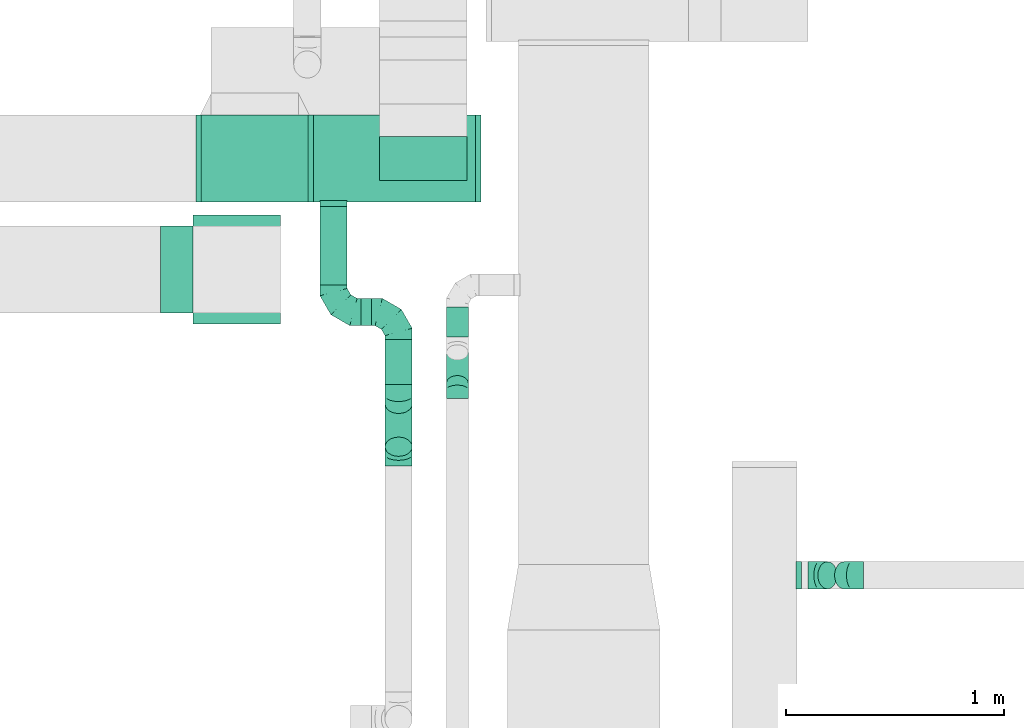
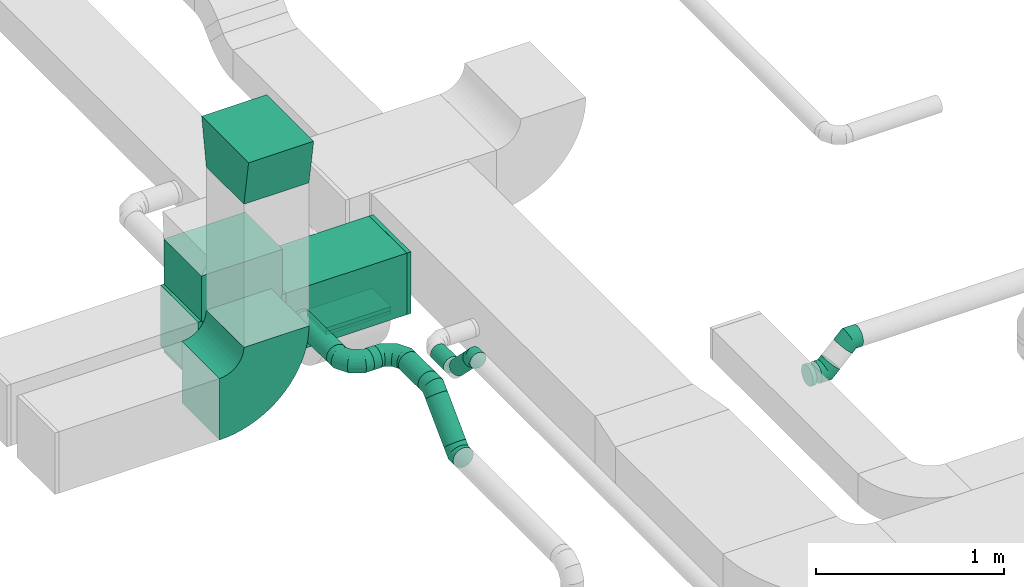
# One storey, part 30 of 60: 16 flow fittings, 9 flow segments.
"""IFC2X3 building model written with IfcOpenShell, lengths in millimetres."""

import ifcopenshell
import ifcopenshell.guid

model = None  # the IFC model being written
_history = None  # IfcOwnerHistory: only IFC2X3 demands one
_inside = {}  # id of a spatial element -> (the spatial element, [elements in it])
_under = {}  # id of a project, library or spatial element -> (it, [spatial elements below it])
_declared = {}  # id of a project -> (the project, [libraries it declares])
_typed = {}  # id of a type object -> (the type object, [elements of that type])
_made_of = {}  # id of a material, layer set ... -> (it, [elements and type objects made of it])


def new_model(schema):
    """Start an empty IFC model of exactly this schema.

    Asked for "IFC4X3", IfcOpenShell would pick the latest addendum, in which some entities
    have other attributes; the version numbers below select the first issue.
    IFC2X3 requires an IfcOwnerHistory on every rooted entity: one is made here for all.
    """
    global model, _history
    if schema == "IFC4X3":
        model = ifcopenshell.file(schema_version=(4, 3, 0, 0))
    else:
        model = ifcopenshell.file(schema=schema)
    _inside.clear()
    _under.clear()
    _declared.clear()
    _typed.clear()
    _made_of.clear()
    _history = None
    if model.schema == "IFC2X3":
        org = make("IfcOrganization", Name="unknown")
        user = make(
            "IfcPersonAndOrganization",
            ThePerson=make("IfcPerson", FamilyName="unknown"),
            TheOrganization=org,
        )
        app = make(
            "IfcApplication",
            ApplicationDeveloper=org,
            Version="unknown",
            ApplicationFullName="unknown",
            ApplicationIdentifier="unknown",
        )
        _history = make(
            "IfcOwnerHistory",
            OwningUser=user,
            OwningApplication=app,
            ChangeAction="ADDED",
            CreationDate=0,
        )
    return model


def make(cls, **values):
    """One entity of the class cls with the attributes given. An attribute that is None is left unset."""
    return model.create_entity(
        cls, **{name: value for name, value in values.items() if value is not None}
    )


def entity(cls, *values):
    """Any entity or typed value of the class cls, its attributes in the order of the schema. None: left unset."""
    e = model.create_entity(cls)
    for i, value in enumerate(values):
        if value is not None:
            e[i] = value
    return e


def rooted(cls, **values):
    """An entity with a GlobalId (a new one), such as an element, a storey or a relation."""
    return make(cls, GlobalId=ifcopenshell.guid.new(), OwnerHistory=_history, **values)


def si_unit(unit_type, name, prefix=None):
    """IfcSIUnit, for example si_unit("LENGTHUNIT", "METRE", prefix="MILLI")."""
    return make("IfcSIUnit", UnitType=unit_type, Prefix=prefix, Name=name)


def converted_unit(unit_type, name, factor, base, dimensions=None, offset=None):
    """IfcConversionBasedUnit, such as the inch: factor (a typed value) times the base unit."""
    return make(
        "IfcConversionBasedUnit"
        if offset is None
        else "IfcConversionBasedUnitWithOffset",
        ConversionOffset=offset,
        Dimensions=None
        if dimensions is None
        else entity("IfcDimensionalExponents", *dimensions),
        UnitType=unit_type,
        Name=name,
        ConversionFactor=make(
            "IfcMeasureWithUnit", ValueComponent=factor, UnitComponent=base
        ),
    )


def derived_unit(unit_type, elements):
    """IfcDerivedUnit: a product of units, each with its exponent."""
    return make(
        "IfcDerivedUnit",
        Elements=[
            make("IfcDerivedUnitElement", Unit=unit, Exponent=power)
            for unit, power in elements
        ],
        UnitType=unit_type,
    )


def assignment(units):
    """IfcUnitAssignment: the units of a project."""
    return None if units is None else make("IfcUnitAssignment", Units=units)


def point(xyz):
    """IfcCartesianPoint."""
    return None if xyz is None else make("IfcCartesianPoint", Coordinates=xyz)


def direction(xyz):
    """IfcDirection."""
    return None if xyz is None else make("IfcDirection", DirectionRatios=xyz)


def frame(location, z_axis=None, x_axis=None):
    """IfcAxis2Placement3D, a coordinate frame: its origin and axes. An axis left out is left unset."""
    return make(
        "IfcAxis2Placement3D",
        Location=point(location),
        Axis=direction(z_axis),
        RefDirection=direction(x_axis),
    )


def frame_2d(location, x_axis=None):
    """IfcAxis2Placement2D, a coordinate frame in the plane: its origin and x axis."""
    return make(
        "IfcAxis2Placement2D", Location=point(location), RefDirection=direction(x_axis)
    )


def origin():
    """The frame at (0, 0, 0) with its axes left unset."""
    return frame((0.0, 0.0, 0.0))


def origin_2d_with_axis():
    """The frame at (0, 0) in the plane with the x axis (1, 0) written out."""
    return frame_2d((0.0, 0.0), x_axis=(1.0, 0.0))


def place(relative_to, where):
    """IfcLocalPlacement: puts the frame where relative to a parent placement (None: the world)."""
    return make(
        "IfcLocalPlacement", PlacementRelTo=relative_to, RelativePlacement=where
    )


def context(
    kind, dimensions, precision=None, world=None, true_north=None, identifier=None
):
    """IfcGeometricRepresentationContext, for example the 3D "Model" context."""
    return make(
        "IfcGeometricRepresentationContext",
        ContextIdentifier=identifier,
        ContextType=kind,
        CoordinateSpaceDimension=dimensions,
        Precision=precision,
        WorldCoordinateSystem=world,
        TrueNorth=true_north,
    )


def subcontext(parent, identifier, kind, view, scale=None):
    """IfcGeometricRepresentationSubContext, for example "Body" below "Model"."""
    return make(
        "IfcGeometricRepresentationSubContext",
        ContextIdentifier=identifier,
        ContextType=kind,
        ParentContext=parent,
        TargetScale=scale,
        TargetView=view,
    )


def project(units=None, contexts=None):
    """IfcProject with its units and contexts."""
    return rooted(
        "IfcProject",
        Name="project",
        RepresentationContexts=contexts,
        UnitsInContext=assignment(units),
    )


def spatial(cls, under=None, at=None, **own):
    """A site, building, storey or space (cls), placed at a placement, below another one or the project."""
    s = rooted(cls, ObjectPlacement=at, **own)
    if under is not None:
        _under.setdefault(under.id(), (under, []))[1].append(s)
    return s


def polyline(points):
    """IfcPolyline through the points."""
    return make("IfcPolyline", Points=[point(p) for p in points])


def circle_curve(where, radius):
    """IfcCircle in the frame where."""
    return make("IfcCircle", Position=where, Radius=radius)


def parameter(value):
    """IfcParameterValue: where a trimmed curve begins or ends, as a parameter of its basis curve."""
    return model.create_entity("IfcParameterValue", value)


def trimmed(basis, trim1, trim2, sense, master):
    """IfcTrimmedCurve: the piece of a basis curve between two trims."""
    return make(
        "IfcTrimmedCurve",
        BasisCurve=basis,
        Trim1=trim1,
        Trim2=trim2,
        SenseAgreement=sense,
        MasterRepresentation=master,
    )


def segment(curve, same_sense, transition):
    """IfcCompositeCurveSegment."""
    return make(
        "IfcCompositeCurveSegment",
        Transition=transition,
        SameSense=same_sense,
        ParentCurve=curve,
    )


def composite_curve(segments, self_intersect=None):
    """IfcCompositeCurve: segments joined end to end."""
    return make("IfcCompositeCurve", Segments=segments, SelfIntersect=self_intersect)


def profile(cls, at=None, kind="AREA", **sizes):
    """A parametric profile (cls). Its sizes go by their IFC names, for example OverallWidth=200.0."""
    return make(cls, ProfileType=kind, Position=at, **sizes)


def rectangle(**sizes):
    """IfcRectangleProfileDef."""
    return profile("IfcRectangleProfileDef", **sizes)


def circle(**sizes):
    """IfcCircleProfileDef."""
    return profile("IfcCircleProfileDef", **sizes)


def outline(outer, holes=None, kind="AREA"):
    """IfcArbitraryClosedProfileDef: a profile drawn as a closed curve; with holes, ...WithVoids."""
    if holes is None:
        return make("IfcArbitraryClosedProfileDef", ProfileType=kind, OuterCurve=outer)
    return make(
        "IfcArbitraryProfileDefWithVoids",
        ProfileType=kind,
        OuterCurve=outer,
        InnerCurves=holes,
    )


def extrude(swept, where, along, depth):
    """IfcExtrudedAreaSolid: the profile swept, set in the frame where, extruded along a direction by depth."""
    return make(
        "IfcExtrudedAreaSolid",
        SweptArea=swept,
        Position=where,
        ExtrudedDirection=direction(along),
        Depth=depth,
    )


def faces_of(points, faces, orient=None, outer=None):
    """IfcFace entities. A face is a list of loops; a loop is a list of indices into points, from 0.

    orient and outer hold one flag for each loop. By default every Orientation is true, the
    first loop of a face is its IfcFaceOuterBound and the others are IfcFaceBound.
    """
    made = []
    for i, loops in enumerate(faces):
        bounds = []
        for j, loop in enumerate(loops):
            is_outer = j == 0 if outer is None else outer[i][j]
            bounds.append(
                make(
                    "IfcFaceOuterBound" if is_outer else "IfcFaceBound",
                    Bound=make("IfcPolyLoop", Polygon=[points[k] for k in loop]),
                    Orientation=True if orient is None else orient[i][j],
                )
            )
        made.append(make("IfcFace", Bounds=bounds))
    return made


def faceted_brep(points, faces, orient=None, outer=None, voids=None):
    """IfcFacetedBrep: a solid bounded by flat faces; with voids (closed shells), ...WithVoids."""
    shared = [point(p) for p in points]
    hull = make("IfcClosedShell", CfsFaces=faces_of(shared, faces, orient, outer))
    if voids is None:
        return make("IfcFacetedBrep", Outer=hull)
    return make(
        "IfcFacetedBrepWithVoids",
        Outer=hull,
        Voids=[
            make(cls, CfsFaces=faces_of(shared, fs, o, b)) for cls, fs, o, b in voids
        ],
    )


def shape(context_of_items, identifier, shape_type, items):
    """IfcShapeRepresentation: the items that make up one representation, for example the "Body"."""
    return make(
        "IfcShapeRepresentation",
        ContextOfItems=context_of_items,
        RepresentationIdentifier=identifier,
        RepresentationType=shape_type,
        Items=items,
    )


def source(mapping_origin, context_of_items, identifier, shape_type, items):
    """IfcRepresentationMap: a shape defined once, which mapped items show again and again."""
    return make(
        "IfcRepresentationMap",
        MappingOrigin=mapping_origin,
        MappedRepresentation=shape(context_of_items, identifier, shape_type, items),
    )


def transform(
    local_origin,
    x_axis=None,
    y_axis=None,
    z_axis=None,
    scale=None,
    scale2=None,
    scale3=None,
    uniform=True,
):
    """IfcCartesianTransformationOperator3D, or its non-uniform kind. x_axis, y_axis, z_axis: its Axis1, 2, 3."""
    if uniform:
        return make(
            "IfcCartesianTransformationOperator3D",
            Axis1=direction(x_axis),
            Axis2=direction(y_axis),
            LocalOrigin=point(local_origin),
            Scale=scale,
            Axis3=direction(z_axis),
        )
    return make(
        "IfcCartesianTransformationOperator3DnonUniform",
        Axis1=direction(x_axis),
        Axis2=direction(y_axis),
        LocalOrigin=point(local_origin),
        Scale=scale,
        Axis3=direction(z_axis),
        Scale2=scale2,
        Scale3=scale3,
    )


def mapped(mapping_source, mapping_target):
    """IfcMappedItem: shows the shape of a source again, moved by a transform."""
    return make(
        "IfcMappedItem", MappingSource=mapping_source, MappingTarget=mapping_target
    )


def material(Name=None, Category=None):
    """IfcMaterial."""
    return make("IfcMaterial", Name=Name, Category=Category)


def made_of(thing, what):
    """Note that an element or type object is made of a material, layer set ...; save() writes the relation."""
    if what is not None:
        _made_of.setdefault(what.id(), (what, []))[1].append(thing)
    return thing


def type_object(cls, material=None, **own):
    """A type object (cls), such as IfcWallType, which elements share."""
    return made_of(rooted(cls, **own), material)


def type_shapes(of_type, sources):
    """Give a type object the sources (RepresentationMaps) that its elements show as mapped items."""
    of_type.RepresentationMaps = sources


def element(
    cls,
    number,
    at=None,
    inside=None,
    cuts=None,
    type_object=None,
    material=None,
    context=None,
    identifier="Body",
    shape_type=None,
    held_by="IfcProductDefinitionShape",
    body=None,
    shapes=None,
    **own,
):
    """One element of the class cls, such as IfcWall. Its Tag is "e" and its number.

    at: its placement. inside: the storey or other place that contains it. cuts: it is an
    opening in that element (IfcRelVoidsElement). A single representation is given by context,
    identifier, shape_type and body (its items); several are given by shapes. held_by: the class
    of the entity that holds the representations. save() writes the other relations.
    """
    e = rooted(cls, Tag="e%d" % number, ObjectPlacement=at, **own)
    if body is not None:
        shapes = [shape(context, identifier, shape_type, body)]
    if shapes is not None:
        e.Representation = make(held_by, Representations=shapes)
    if inside is not None:
        _inside.setdefault(inside.id(), (inside, []))[1].append(e)
    if cuts is not None:
        rooted(
            "IfcRelVoidsElement", RelatingBuildingElement=cuts, RelatedOpeningElement=e
        )
    if type_object is not None:
        _typed.setdefault(type_object.id(), (type_object, []))[1].append(e)
    return made_of(e, material)


def aggregate(whole, parts):
    """IfcRelAggregates: a whole, such as a stair, and the parts it consists of."""
    return rooted("IfcRelAggregates", RelatingObject=whole, RelatedObjects=parts)


def save(model, path):
    """Write the relations noted so far, then the file.

    IfcRelAggregates (storeys below a building ...), IfcRelContainedInSpatialStructure (elements
    in a storey), IfcRelDefinesByType, IfcRelAssociatesMaterial and IfcRelDeclares: one each for
    every whole, place, type object, material and project.
    """
    for whole, parts in _under.values():
        aggregate(whole, parts)
    for where, things in _inside.values():
        rooted(
            "IfcRelContainedInSpatialStructure",
            RelatedElements=things,
            RelatingStructure=where,
        )
    for kind, things in _typed.values():
        rooted("IfcRelDefinesByType", RelatedObjects=things, RelatingType=kind)
    for what, things in _made_of.values():
        rooted("IfcRelAssociatesMaterial", RelatedObjects=things, RelatingMaterial=what)
    for by, libraries in _declared.values():
        rooted("IfcRelDeclares", RelatingContext=by, RelatedDefinitions=libraries)
    model.write(path)


model = new_model("IFC2X3")

# Units and contexts
model_context = context("Model", 3, precision=0.01, world=origin(), true_north=direction((6.12303176911189e-17, 1.0)))
body_context = subcontext(model_context, "Body", "Model", "MODEL_VIEW")
ifc_project = project(units=[si_unit("LENGTHUNIT", "METRE", prefix="MILLI"), si_unit("AREAUNIT", "SQUARE_METRE"), si_unit("VOLUMEUNIT", "CUBIC_METRE"), converted_unit("PLANEANGLEUNIT", "DEGREE", entity("IfcRatioMeasure", 0.0174532925199433), si_unit("PLANEANGLEUNIT", "RADIAN"), dimensions=[0, 0, 0, 0, 0, 0, 0]), si_unit("MASSUNIT", "GRAM", prefix="KILO"), derived_unit("MASSDENSITYUNIT", [(si_unit("MASSUNIT", "GRAM", prefix="KILO"), 1), (si_unit("LENGTHUNIT", "METRE"), -3)]), derived_unit("MOMENTOFINERTIAUNIT", [(si_unit("LENGTHUNIT", "METRE"), 4)]), si_unit("TIMEUNIT", "SECOND"), si_unit("FREQUENCYUNIT", "HERTZ"), si_unit("THERMODYNAMICTEMPERATUREUNIT", "DEGREE_CELSIUS"), derived_unit("THERMALTRANSMITTANCEUNIT", [(si_unit("MASSUNIT", "GRAM", prefix="KILO"), 1), (si_unit("THERMODYNAMICTEMPERATUREUNIT", "KELVIN"), -1), (si_unit("TIMEUNIT", "SECOND"), -3)]), derived_unit("VOLUMETRICFLOWRATEUNIT", [(si_unit("LENGTHUNIT", "METRE"), 3), (si_unit("TIMEUNIT", "SECOND"), -1)]), derived_unit("MASSFLOWRATEUNIT", [(si_unit("MASSUNIT", "GRAM", prefix="KILO"), 1), (si_unit("TIMEUNIT", "SECOND"), -1)]), derived_unit("ROTATIONALFREQUENCYUNIT", [(si_unit("TIMEUNIT", "SECOND"), -1)]), si_unit("ELECTRICCURRENTUNIT", "AMPERE"), si_unit("ELECTRICVOLTAGEUNIT", "VOLT"), si_unit("POWERUNIT", "WATT"), si_unit("FORCEUNIT", "NEWTON", prefix="KILO"), si_unit("ILLUMINANCEUNIT", "LUX"), si_unit("LUMINOUSFLUXUNIT", "LUMEN"), si_unit("LUMINOUSINTENSITYUNIT", "CANDELA"), derived_unit("USERDEFINED", [(si_unit("MASSUNIT", "GRAM", prefix="KILO"), -1), (si_unit("LENGTHUNIT", "METRE"), -2), (si_unit("TIMEUNIT", "SECOND"), 3), (si_unit("LUMINOUSFLUXUNIT", "LUMEN"), 1)]), derived_unit("LINEARVELOCITYUNIT", [(si_unit("LENGTHUNIT", "METRE"), 1), (si_unit("TIMEUNIT", "SECOND"), -1)]), si_unit("PRESSUREUNIT", "PASCAL"), derived_unit("USERDEFINED", [(si_unit("LENGTHUNIT", "METRE"), -2), (si_unit("MASSUNIT", "GRAM", prefix="KILO"), 1), (si_unit("TIMEUNIT", "SECOND"), -2)]), derived_unit("LINEARFORCEUNIT", [(si_unit("MASSUNIT", "GRAM", prefix="KILO"), 1), (si_unit("LENGTHUNIT", "METRE"), 1), (si_unit("TIMEUNIT", "SECOND"), -2), (si_unit("LENGTHUNIT", "METRE"), -1)]), derived_unit("PLANARFORCEUNIT", [(si_unit("MASSUNIT", "GRAM", prefix="KILO"), 1), (si_unit("LENGTHUNIT", "METRE"), 1), (si_unit("TIMEUNIT", "SECOND"), -2), (si_unit("LENGTHUNIT", "METRE"), -2)])], contexts=[model_context])

# Site, building, storey
site_placement = place(None, origin())
site = spatial("IfcSite", under=ifc_project, at=site_placement, CompositionType="ELEMENT")
building_placement = place(site_placement, origin())
building = spatial("IfcBuilding", under=site, at=building_placement, CompositionType="ELEMENT")
storey_placement = place(building_placement, frame((0.0, 0.0, 19800.0)))
storey = spatial("IfcBuildingStorey", under=building, at=storey_placement, CompositionType="ELEMENT", Elevation=19800.0)

# Flow segments
duct_segment_type_1 = type_object("IfcDuctSegmentType", PredefinedType="NOTDEFINED")
flow_segment_1_placement = place(storey_placement, frame((42550.17, 11999.48, 3370.0)))
element("IfcFlowSegment", 1, at=flow_segment_1_placement, inside=storey, type_object=duct_segment_type_1, context=body_context, shape_type="SweptSolid", body=[
    extrude(rectangle(XDim=742.969559856747, YDim=400.0, at=origin_2d_with_axis()), frame((371.48, 200.0, 0.0)), (0.0, 0.0, 1.0), 400.000000000004),
])
flow_segment_2_placement = place(storey_placement, frame((42853.67, 12099.48, 3330.0)))
element("IfcFlowSegment", 2, at=flow_segment_2_placement, inside=storey, type_object=duct_segment_type_1, context=body_context, shape_type="SweptSolid", body=[
    extrude(rectangle(XDim=199.999999999998, YDim=400.000000000004, at=origin_2d_with_axis()), frame((200.0, 100.0, 0.0), z_axis=(0.0, 0.0, 1.0), x_axis=(0.0, 1.0, 0.0)), (0.0, 0.0, 1.0), 20.0000000000084),
])
flow_segment_3_placement = place(storey_placement, frame((42030.17, 11999.85, 3351.84)))
element("IfcFlowSegment", 3, at=flow_segment_3_placement, inside=storey, type_object=duct_segment_type_1, context=body_context, shape_type="SweptSolid", body=[
    extrude(rectangle(XDim=400.0, YDim=499.999999999999, at=origin_2d_with_axis()), frame((250.0, 200.0, 0.0), z_axis=(0.0, 0.0, 1.0), x_axis=(0.0, 1.0, 0.0)), (0.0, 0.0, 1.0), 710.827055832312),
])
duct_segment_type_2 = type_object("IfcDuctSegmentType", PredefinedType="NOTDEFINED")
flow_segment_4_placement = place(storey_placement, frame((42577.71, 11619.48, 3505.9)))
element("IfcFlowSegment", 4, at=flow_segment_4_placement, inside=storey, type_object=duct_segment_type_2, context=body_context, shape_type="SweptSolid", body=[
    extrude(circle(Radius=62.5, at=origin_2d_with_axis()), frame((64.1, 0.0, 64.1), z_axis=(0.0, 1.0, 0.0), x_axis=(-1.0, 0.0, 0.0)), (0.0, 0.0, 1.0), 359.999999999987),
])
flow_segment_5_placement = place(storey_placement, frame((42766.81, 11430.38, 3505.9)))
element("IfcFlowSegment", 5, at=flow_segment_5_placement, inside=storey, type_object=duct_segment_type_2, context=body_context, shape_type="SweptSolid", body=[
    extrude(circle(Radius=62.5, at=origin_2d_with_axis()), frame((0.0, 64.1, 64.1), z_axis=(1.0, 0.0, 0.0), x_axis=(0.0, -1.0, 0.0)), (0.0, 0.0, 1.0), 48.7500000000279),
])
flow_segment_6_placement = place(storey_placement, frame((42876.46, 11161.25, 3505.9)))
element("IfcFlowSegment", 6, at=flow_segment_6_placement, inside=storey, type_object=duct_segment_type_2, context=body_context, shape_type="SweptSolid", body=[
    extrude(circle(Radius=62.5, at=origin_2d_with_axis()), frame((64.1, 0.0, 64.1), z_axis=(0.0, 1.0, 0.0), x_axis=(-1.0, 0.0, 0.0)), (0.0, 0.0, 1.0), 208.223304703391),
])
flow_segment_7_placement = place(storey_placement, frame((42876.46, 10830.3, 3290.82)))
element("IfcFlowSegment", 7, at=flow_segment_7_placement, inside=storey, type_object=duct_segment_type_2, context=body_context, shape_type="SweptSolid", body=[
    extrude(circle(Radius=62.5, at=origin_2d_with_axis()), frame((64.1, 45.79, 45.79), z_axis=(0.0, 0.707106781186545, 0.70710678118655), x_axis=(-1.0, 0.0, 0.0)), (0.0, 0.0, 1.0), 278.284271247549),
])
flow_segment_8_placement = place(storey_placement, frame((43158.68, 11379.56, 3398.4)))
element("IfcFlowSegment", 8, at=flow_segment_8_placement, inside=storey, type_object=duct_segment_type_2, context=body_context, shape_type="SweptSolid", body=[
    extrude(circle(Radius=50.0, at=origin_2d_with_axis()), frame((51.6, 0.0, 51.6), z_axis=(0.0, 1.0, 0.0), x_axis=(-1.0, 0.0, 0.0)), (0.0, 0.0, 1.0), 138.578643762691),
])
flow_segment_9_placement = place(storey_placement, frame((43158.68, 11130.48, 3442.34)))
element("IfcFlowSegment", 9, at=flow_segment_9_placement, inside=storey, type_object=duct_segment_type_2, context=body_context, shape_type="SweptSolid", body=[
    extrude(circle(Radius=50.0, at=origin_2d_with_axis()), frame((51.6, 36.95, 178.37), z_axis=(0.0, 0.707106781186548, -0.707106781186548), x_axis=(-1.0, 0.0, 0.0)), (0.0, 0.0, 1.0), 200.000000000068),
])

# Flow fittings
ifc_material = material()
duct_fitting_type_1 = type_object("IfcDuctFittingType", PredefinedType="NOTDEFINED", material=ifc_material)
shared_shape_1 = source(origin(), body_context, "Body", "SweptSolid", [
    extrude(rectangle(XDim=24.9999999999999, YDim=500.0, at=origin_2d_with_axis()), frame((12.5, 0.0, -200.0)), (0.0, 0.0, 1.0), 400.0),
])
type_shapes(duct_fitting_type_1, [shared_shape_1])
flow_fitting_1_placement = place(storey_placement, frame((42280.17, 12199.48, 3351.84), z_axis=(0.0, -1.0, 0.0), x_axis=(0.0, 0.0, -1.0)))
element("IfcFlowFitting", 10, at=flow_fitting_1_placement, inside=storey, type_object=duct_fitting_type_1, material=ifc_material, context=body_context, shape_type="MappedRepresentation", body=[
    mapped(shared_shape_1, transform((0.0, 0.0, 0.0), scale=1.0)),
])
duct_fitting_type_2 = type_object("IfcDuctFittingType", PredefinedType="NOTDEFINED", material=ifc_material)
shared_shape_2 = source(origin(), body_context, "Body", "SweptSolid", [
    extrude(rectangle(XDim=26.0960000000093, YDim=400.0, at=origin_2d_with_axis()), frame((6.95, 0.0, -200.0)), (0.0, 0.0, 1.0), 400.0),
])
type_shapes(duct_fitting_type_2, [shared_shape_2])
for number, where, z_axis, x_axis in (
    (11, (42530.17, 12199.48, 3570.0), (0.0, -1.0, 0.0), (1.0, 0.0, 0.0)),
    (12, (42030.17, 12199.48, 3570.0), (0.0, 1.0, 0.0), (-1.0, 0.0, 0.0)),
):
    element("IfcFlowFitting", number, at=place(storey_placement, frame(where, z_axis=z_axis, x_axis=x_axis)), inside=storey, type_object=duct_fitting_type_2, material=ifc_material, context=body_context, shape_type="MappedRepresentation", body=[
        mapped(shared_shape_2, transform((0.0, 0.0, 0.0), scale=1.0)),
    ])
duct_fitting_type_3 = type_object("IfcDuctFittingType", PredefinedType="NOTDEFINED", material=ifc_material)
shared_shape_3 = source(origin(), body_context, "Body", "SweptSolid", [
    extrude(rectangle(XDim=200.0, YDim=26.096, at=origin_2d_with_axis()), frame((6.95, 0.0, -200.0), z_axis=(0.0, 0.0, 1.0), x_axis=(0.0, -1.0, 0.0)), (0.0, 0.0, 1.0), 400.0),
])
type_shapes(duct_fitting_type_3, [shared_shape_3])
flow_fitting_2_placement = place(storey_placement, frame((43053.67, 12199.48, 3370.0), z_axis=(-1.0, 0.0, 0.0), x_axis=(0.0, 0.0, -1.0)))
element("IfcFlowFitting", 13, at=flow_fitting_2_placement, inside=storey, type_object=duct_fitting_type_3, material=ifc_material, context=body_context, shape_type="MappedRepresentation", body=[
    mapped(shared_shape_3, transform((0.0, 0.0, 0.0), scale=1.0)),
])
duct_fitting_type_4 = type_object("IfcDuctFittingType", PredefinedType="NOTDEFINED", material=ifc_material)
shared_shape_4 = source(origin(), body_context, "Body", "SweptSolid", [
    extrude(rectangle(XDim=24.9999999999999, YDim=400.0, at=origin_2d_with_axis()), frame((12.5, 0.0, -200.0)), (0.0, 0.0, 1.0), 400.0),
])
type_shapes(duct_fitting_type_4, [shared_shape_4])
flow_fitting_3_placement = place(storey_placement, frame((43293.14, 12199.48, 3570.0)))
element("IfcFlowFitting", 14, at=flow_fitting_3_placement, inside=storey, type_object=duct_fitting_type_4, material=ifc_material, context=body_context, shape_type="MappedRepresentation", body=[
    mapped(shared_shape_4, transform((0.0, 0.0, 0.0), scale=1.0)),
])
duct_fitting_type_5 = type_object("IfcDuctFittingType", PredefinedType="NOTDEFINED", material=ifc_material)
shared_shape_5 = source(origin(), body_context, "Body", "SweptSolid", [
    extrude(outline(polyline([(-115.08, -221.94), (189.06, -221.94), (106.86, 271.26), (-180.84, 172.62), (-115.08, -221.94)])), frame((150.0, 0.0, -200.0), z_axis=(0.0, 0.0, 1.0), x_axis=(0.986393923832143, -0.164398987305359, 0.0)), (0.0, 0.0, 1.0), 400.0),
])
type_shapes(duct_fitting_type_5, [shared_shape_5])
flow_fitting_4_placement = place(storey_placement, frame((42197.64, 11690.3, 4850.0), z_axis=(1.0, 0.0, 0.0), x_axis=(0.0, 0.0, 1.0)))
element("IfcFlowFitting", 15, at=flow_fitting_4_placement, inside=storey, type_object=duct_fitting_type_5, material=ifc_material, context=body_context, shape_type="MappedRepresentation", body=[
    mapped(shared_shape_5, transform((0.0, 0.0, 0.0), scale=1.0)),
])
duct_fitting_type_6 = type_object("IfcDuctFittingType", PredefinedType="NOTDEFINED", material=ifc_material)
shared_shape_6 = source(origin(), body_context, "Body", "Brep", [
    faceted_brep([(-125.0, 0.0, -62.5), (-125.0, -16.18, -60.37), (-125.0, -31.25, -54.13), (-125.0, -44.19, -44.19), (-125.0, -54.13, -31.25), (-125.0, -60.37, -16.18), (-125.0, -62.5, 0.0), (-125.0, -60.37, 16.18), (-125.0, -54.13, 31.25), (-125.0, -44.19, 44.19), (-125.0, -31.25, 54.13), (-125.0, -16.18, 60.37), (-125.0, 0.0, 62.5), (-125.0, 16.18, 60.37), (-125.0, 31.25, 54.13), (-125.0, 44.19, 44.19), (-125.0, 54.13, 31.25), (-125.0, 60.37, 16.18), (-125.0, 62.5, 0.0), (-125.0, 60.37, -16.18), (-125.0, 54.13, -31.25), (-125.0, 44.19, -44.19), (-125.0, 31.25, -54.13), (-125.0, 16.18, -60.37), (-95.84, 16.18, 60.37), (-99.88, 31.25, 54.13), (-91.51, 0.0, 62.5), (-103.35, 44.19, 44.19), (-107.68, 60.37, 16.18), (-108.25, 62.5, 0.0), (-106.01, 54.13, 31.25), (-106.01, 54.13, -31.25), (-103.35, 44.19, -44.19), (-107.68, 60.37, -16.18), (-95.84, 16.18, -60.37), (-91.51, 0.0, -62.5), (-99.88, 31.25, -54.13), (-87.17, -16.18, -60.37), (-83.13, -31.25, -54.13), (-79.66, -44.19, -44.19), (-77.0, -54.13, -31.25), (-75.33, -60.37, -16.18), (-74.76, -62.5, 0.0), (-75.33, -60.37, 16.18), (-77.0, -54.13, 31.25), (-79.66, -44.19, 44.19), (-83.13, -31.25, 54.13), (-87.17, -16.18, 60.37), (-45.34, 45.34, 60.37), (-56.37, 56.37, 54.13), (-33.49, 33.49, 62.5), (-65.85, 65.85, 44.19), (-73.12, 73.12, 31.25), (-77.69, 77.69, 16.18), (-79.25, 79.25, 0.0), (-77.69, 77.69, -16.18), (-73.12, 73.12, -31.25), (-65.85, 65.85, -44.19), (-45.34, 45.34, -60.37), (-33.49, 33.49, -62.5), (-56.37, 56.37, -54.13), (-21.65, 21.65, -60.37), (-10.62, 10.62, -54.13), (-1.14, 1.14, -44.19), (6.13, -6.13, -31.25), (10.7, -10.7, -16.18), (12.26, -12.26, 0.0), (10.7, -10.7, 16.18), (6.13, -6.13, 31.25), (-1.14, 1.14, 44.19), (-10.62, 10.62, 54.13), (-21.65, 21.65, 60.37), (-16.18, 95.84, 60.37), (-31.25, 99.88, 54.13), (0.0, 91.51, 62.5), (-44.19, 103.35, 44.19), (-54.13, 106.01, 31.25), (-60.37, 107.68, 16.18), (-62.5, 108.25, 0.0), (-60.37, 107.68, -16.18), (-54.13, 106.01, -31.25), (-44.19, 103.35, -44.19), (-16.18, 95.84, -60.37), (0.0, 91.51, -62.5), (-31.25, 99.88, -54.13), (16.18, 87.17, -60.37), (31.25, 83.13, -54.13), (44.19, 79.66, -44.19), (54.13, 77.0, -31.25), (60.37, 75.33, -16.18), (62.5, 74.76, 0.0), (60.37, 75.33, 16.18), (54.13, 77.0, 31.25), (44.19, 79.66, 44.19), (31.25, 83.13, 54.13), (16.18, 87.17, 60.37), (-16.18, 125.0, -60.37), (-31.25, 125.0, -54.13), (-44.19, 125.0, -44.19), (-54.13, 125.0, -31.25), (-60.37, 125.0, -16.18), (-62.5, 125.0, 0.0), (-60.37, 125.0, 16.18), (-54.13, 125.0, 31.25), (-44.19, 125.0, 44.19), (-31.25, 125.0, 54.13), (-16.18, 125.0, 60.37), (0.0, 125.0, 62.5), (16.18, 125.0, 60.37), (31.25, 125.0, 54.13), (44.19, 125.0, 44.19), (54.13, 125.0, 31.25), (60.37, 125.0, 16.18), (62.5, 125.0, 0.0), (60.37, 125.0, -16.18), (54.13, 125.0, -31.25), (44.19, 125.0, -44.19), (31.25, 125.0, -54.13), (16.18, 125.0, -60.37), (0.0, 125.0, -62.5)], [[[0, 1, 2, 3, 4, 5, 6, 7, 8, 9, 10, 11, 12, 13, 14, 15, 16, 17, 18, 19, 20, 21, 22, 23]], [[24, 25, 14, 13]], [[26, 24, 13, 12]], [[14, 25, 27, 15]], [[28, 29, 18, 17]], [[30, 28, 17, 16]], [[15, 27, 30, 16]], [[20, 31, 32, 21]], [[33, 31, 20, 19]], [[18, 29, 33, 19]], [[34, 35, 0, 23]], [[36, 34, 23, 22]], [[21, 32, 36, 22]], [[1, 0, 35, 37]], [[2, 1, 37, 38]], [[38, 39, 3, 2]], [[5, 4, 40, 41]], [[6, 5, 41, 42]], [[39, 40, 4, 3]], [[6, 42, 43, 7]], [[7, 43, 44, 8]], [[45, 9, 8, 44]], [[9, 45, 46, 10]], [[10, 46, 47, 11]], [[26, 12, 11, 47]], [[48, 49, 25, 24]], [[50, 48, 24, 26]], [[27, 25, 49, 51]], [[52, 53, 28, 30]], [[51, 52, 30, 27]], [[29, 28, 53, 54]], [[55, 56, 31, 33]], [[54, 55, 33, 29]], [[57, 32, 31, 56]], [[58, 59, 35, 34]], [[60, 58, 34, 36]], [[57, 60, 36, 32]], [[37, 35, 59, 61]], [[38, 37, 61, 62]], [[39, 38, 62, 63]], [[41, 40, 64, 65]], [[42, 41, 65, 66]], [[63, 64, 40, 39]], [[43, 42, 66, 67]], [[44, 43, 67, 68]], [[68, 69, 45, 44]], [[46, 45, 69, 70]], [[47, 46, 70, 71]], [[26, 47, 71, 50]], [[72, 73, 49, 48]], [[74, 72, 48, 50]], [[51, 49, 73, 75]], [[76, 77, 53, 52]], [[75, 76, 52, 51]], [[54, 53, 77, 78]], [[79, 80, 56, 55]], [[78, 79, 55, 54]], [[81, 57, 56, 80]], [[82, 83, 59, 58]], [[84, 82, 58, 60]], [[81, 84, 60, 57]], [[61, 59, 83, 85]], [[62, 61, 85, 86]], [[63, 62, 86, 87]], [[65, 64, 88, 89]], [[66, 65, 89, 90]], [[87, 88, 64, 63]], [[67, 66, 90, 91]], [[68, 67, 91, 92]], [[92, 93, 69, 68]], [[70, 69, 93, 94]], [[71, 70, 94, 95]], [[50, 71, 95, 74]], [[96, 97, 98, 99, 100, 101, 102, 103, 104, 105, 106, 107, 108, 109, 110, 111, 112, 113, 114, 115, 116, 117, 118, 119]], [[72, 74, 107, 106]], [[73, 72, 106, 105]], [[75, 73, 105, 104]], [[77, 76, 103, 102]], [[78, 77, 102, 101]], [[75, 104, 103, 76]], [[78, 101, 100, 79]], [[79, 100, 99, 80]], [[80, 99, 98, 81]], [[96, 119, 83, 82]], [[97, 96, 82, 84]], [[84, 81, 98, 97]], [[83, 119, 118, 85]], [[85, 118, 117, 86]], [[116, 87, 86, 117]], [[88, 115, 114, 89]], [[89, 114, 113, 90]], [[115, 88, 87, 116]], [[91, 90, 113, 112]], [[92, 91, 112, 111]], [[111, 110, 93, 92]], [[95, 94, 109, 108]], [[74, 95, 108, 107]], [[110, 109, 94, 93]]]),
])
type_shapes(duct_fitting_type_6, [shared_shape_6])
for number, where, z_axis, x_axis in (
    (16, (42641.81, 11494.48, 3570.0), (0.0, 0.0, 1.0), (0.0, -1.0, 0.0)),
    (17, (42940.56, 11494.48, 3570.0), (0.0, 0.0, 1.0), (0.0, 1.0, 0.0)),
):
    element("IfcFlowFitting", number, at=place(storey_placement, frame(where, z_axis=z_axis, x_axis=x_axis)), inside=storey, type_object=duct_fitting_type_6, material=ifc_material, context=body_context, shape_type="MappedRepresentation", body=[
        mapped(shared_shape_6, transform((0.0, 0.0, 0.0), scale=1.0)),
    ])
duct_fitting_type_7 = type_object("IfcDuctFittingType", PredefinedType="NOTDEFINED", material=ifc_material)
shared_shape_7 = source(origin(), body_context, "Body", "Brep", [
    faceted_brep([(-51.78, 0.0, -62.5), (-51.78, -16.18, -60.37), (-51.78, -31.25, -54.13), (-51.78, -44.19, -44.19), (-51.78, -54.13, -31.25), (-51.78, -60.37, -16.18), (-51.78, -62.5, 0.0), (-51.78, -60.37, 16.18), (-51.78, -54.13, 31.25), (-51.78, -44.19, 44.19), (-51.78, -31.25, 54.13), (-51.78, -16.18, 60.37), (-51.78, 0.0, 62.5), (-51.78, 16.18, 60.37), (-51.78, 31.25, 54.13), (-51.78, 44.19, 44.19), (-51.78, 54.13, 31.25), (-51.78, 60.37, 16.18), (-51.78, 62.5, 0.0), (-51.78, 60.37, -16.18), (-51.78, 54.13, -31.25), (-51.78, 44.19, -44.19), (-51.78, 31.25, -54.13), (-51.78, 16.18, -60.37), (-6.7, 16.18, 60.37), (-12.94, 31.25, 54.13), (0.0, 0.0, 62.5), (-18.31, 44.19, 44.19), (-22.42, 54.13, 31.25), (-25.01, 60.37, 16.18), (-25.89, 62.5, 0.0), (-25.01, 60.37, -16.18), (-22.42, 54.13, -31.25), (-18.31, 44.19, -44.19), (-6.7, 16.18, -60.37), (0.0, 0.0, -62.5), (-12.94, 31.25, -54.13), (6.7, -16.18, -60.37), (12.94, -31.25, -54.13), (18.31, -44.19, -44.19), (22.42, -54.13, -31.25), (25.01, -60.37, -16.18), (25.89, -62.5, 0.0), (25.01, -60.37, 16.18), (22.42, -54.13, 31.25), (18.31, -44.19, 44.19), (12.94, -31.25, 54.13), (6.7, -16.18, 60.37), (25.17, 48.05, 60.37), (14.51, 58.71, 54.13), (36.61, 36.61, 62.5), (5.36, 67.86, 44.19), (-1.66, 74.88, 31.25), (-6.08, 79.3, 16.18), (-7.58, 80.81, 0.0), (-6.08, 79.3, -16.18), (-1.66, 74.88, -31.25), (5.36, 67.86, -44.19), (14.51, 58.71, -54.13), (25.17, 48.05, -60.37), (36.61, 36.61, -62.5), (48.05, 25.17, -60.37), (58.71, 14.51, -54.13), (67.86, 5.36, -44.19), (74.88, -1.66, -31.25), (79.3, -6.08, -16.18), (80.81, -7.58, 0.0), (79.3, -6.08, 16.18), (74.88, -1.66, 31.25), (67.86, 5.36, 44.19), (58.71, 14.51, 54.13), (48.05, 25.17, 60.37)], [[[0, 1, 2, 3, 4, 5, 6, 7, 8, 9, 10, 11, 12, 13, 14, 15, 16, 17, 18, 19, 20, 21, 22, 23]], [[24, 25, 14, 13]], [[26, 24, 13, 12]], [[27, 15, 14, 25]], [[28, 29, 17, 16]], [[28, 16, 15, 27]], [[30, 18, 17, 29]], [[31, 32, 20, 19]], [[30, 31, 19, 18]], [[21, 20, 32, 33]], [[34, 35, 0, 23]], [[36, 34, 23, 22]], [[33, 36, 22, 21]], [[1, 0, 35, 37]], [[2, 1, 37, 38]], [[38, 39, 3, 2]], [[5, 4, 40, 41]], [[6, 5, 41, 42]], [[39, 40, 4, 3]], [[6, 42, 43, 7]], [[7, 43, 44, 8]], [[8, 44, 45, 9]], [[9, 45, 46, 10]], [[10, 46, 47, 11]], [[26, 12, 11, 47]], [[48, 49, 25, 24]], [[50, 48, 24, 26]], [[27, 25, 49, 51]], [[29, 28, 52, 53]], [[30, 29, 53, 54]], [[51, 52, 28, 27]], [[30, 54, 55, 31]], [[31, 55, 56, 32]], [[57, 33, 32, 56]], [[36, 58, 59, 34]], [[34, 59, 60, 35]], [[58, 36, 33, 57]], [[35, 60, 61, 37]], [[37, 61, 62, 38]], [[63, 39, 38, 62]], [[40, 64, 65, 41]], [[41, 65, 66, 42]], [[64, 40, 39, 63]], [[43, 42, 66, 67]], [[44, 43, 67, 68]], [[68, 69, 45, 44]], [[47, 46, 70, 71]], [[26, 47, 71, 50]], [[69, 70, 46, 45]], [[59, 58, 57, 56, 55, 54, 53, 52, 51, 49, 48, 50, 71, 70, 69, 68, 67, 66, 65, 64, 63, 62, 61, 60]]]),
])
type_shapes(duct_fitting_type_7, [shared_shape_7])
for number, where, z_axis, x_axis in (
    (18, (42940.56, 11109.48, 3570.0), (1.0, 0.0, 0.0), (0.0, -1.0, 0.0)),
    (19, (42940.56, 10839.48, 3300.0), (-1.0, 0.0, 0.0), (0.0, -0.707106781186497, -0.707106781186598)),
):
    element("IfcFlowFitting", number, at=place(storey_placement, frame(where, z_axis=z_axis, x_axis=x_axis)), inside=storey, type_object=duct_fitting_type_7, material=ifc_material, context=body_context, shape_type="MappedRepresentation", body=[
        mapped(shared_shape_7, transform((0.0, 0.0, 0.0), scale=1.0)),
    ])
duct_fitting_type_8 = type_object("IfcDuctFittingType", PredefinedType="NOTDEFINED", material=ifc_material)
type_shapes(duct_fitting_type_8, [shared_shape_7])
for number, where, z_axis, x_axis in (
    (20, (44872.7, 10285.62, 3500.0), (0.0, -1.0, 0.0), (1.0, 0.0, 0.0)),
    (21, (45022.7, 10285.62, 3650.0), (0.0, 1.0, 0.0), (0.707106792500505, 0.0, 0.707106769872589)),
):
    element("IfcFlowFitting", number, at=place(storey_placement, frame(where, z_axis=z_axis, x_axis=x_axis)), inside=storey, type_object=duct_fitting_type_8, material=ifc_material, context=body_context, shape_type="MappedRepresentation", body=[
        mapped(shared_shape_7, transform((0.0, 0.0, 0.0), scale=1.0)),
    ])
duct_fitting_type_9 = type_object("IfcDuctFittingType", PredefinedType="NOTDEFINED", material=ifc_material)
shared_shape_8 = source(origin(), body_context, "Body", "Brep", [
    faceted_brep([(-41.42, 0.0, -50.0), (-41.42, -12.94, -48.3), (-41.42, -25.0, -43.3), (-41.42, -35.36, -35.36), (-41.42, -43.3, -25.0), (-41.42, -48.3, -12.94), (-41.42, -50.0, 0.0), (-41.42, -48.3, 12.94), (-41.42, -43.3, 25.0), (-41.42, -35.36, 35.36), (-41.42, -25.0, 43.3), (-41.42, -12.94, 48.3), (-41.42, 0.0, 50.0), (-41.42, 12.94, 48.3), (-41.42, 25.0, 43.3), (-41.42, 35.36, 35.36), (-41.42, 43.3, 25.0), (-41.42, 48.3, 12.94), (-41.42, 50.0, 0.0), (-41.42, 48.3, -12.94), (-41.42, 43.3, -25.0), (-41.42, 35.36, -35.36), (-41.42, 25.0, -43.3), (-41.42, 12.94, -48.3), (-5.36, 12.94, 48.3), (-10.36, 25.0, 43.3), (0.0, 0.0, 50.0), (-14.64, 35.36, 35.36), (-20.0, 48.3, 12.94), (-20.71, 50.0, 0.0), (-17.94, 43.3, 25.0), (-17.94, 43.3, -25.0), (-14.64, 35.36, -35.36), (-20.0, 48.3, -12.94), (-5.36, 12.94, -48.3), (0.0, 0.0, -50.0), (-10.36, 25.0, -43.3), (5.36, -12.94, -48.3), (10.36, -25.0, -43.3), (14.64, -35.36, -35.36), (17.94, -43.3, -25.0), (20.0, -48.3, -12.94), (20.71, -50.0, 0.0), (20.0, -48.3, 12.94), (17.94, -43.3, 25.0), (14.64, -35.36, 35.36), (10.36, -25.0, 43.3), (5.36, -12.94, 48.3), (29.29, 29.29, 50.0), (20.14, 38.44, 48.3), (11.61, 46.97, 43.3), (4.29, 54.29, 35.36), (-1.33, 59.91, 25.0), (-4.86, 63.44, 12.94), (-6.07, 64.64, 0.0), (-4.86, 63.44, -12.94), (-1.33, 59.91, -25.0), (4.29, 54.29, -35.36), (11.61, 46.97, -43.3), (20.14, 38.44, -48.3), (29.29, 29.29, -50.0), (38.44, 20.14, -48.3), (46.97, 11.61, -43.3), (54.29, 4.29, -35.36), (59.91, -1.33, -25.0), (63.44, -4.86, -12.94), (64.64, -6.07, 0.0), (63.44, -4.86, 12.94), (59.91, -1.33, 25.0), (54.29, 4.29, 35.36), (46.97, 11.61, 43.3), (38.44, 20.14, 48.3)], [[[0, 1, 2, 3, 4, 5, 6, 7, 8, 9, 10, 11, 12, 13, 14, 15, 16, 17, 18, 19, 20, 21, 22, 23]], [[24, 25, 14, 13]], [[26, 24, 13, 12]], [[14, 25, 27, 15]], [[28, 29, 18, 17]], [[30, 28, 17, 16]], [[16, 15, 27, 30]], [[20, 31, 32, 21]], [[33, 31, 20, 19]], [[18, 29, 33, 19]], [[34, 35, 0, 23]], [[36, 34, 23, 22]], [[32, 36, 22, 21]], [[1, 0, 35, 37]], [[2, 1, 37, 38]], [[38, 39, 3, 2]], [[5, 4, 40, 41]], [[6, 5, 41, 42]], [[39, 40, 4, 3]], [[6, 42, 43, 7]], [[7, 43, 44, 8]], [[8, 44, 45, 9]], [[9, 45, 46, 10]], [[10, 46, 47, 11]], [[26, 12, 11, 47]], [[24, 26, 48, 49]], [[25, 24, 49, 50]], [[27, 25, 50, 51]], [[28, 30, 52, 53]], [[29, 28, 53, 54]], [[27, 51, 52, 30]], [[29, 54, 55, 33]], [[33, 55, 56, 31]], [[31, 56, 57, 32]], [[36, 58, 59, 34]], [[34, 59, 60, 35]], [[36, 32, 57, 58]], [[61, 62, 38, 37]], [[60, 61, 37, 35]], [[63, 39, 38, 62]], [[40, 64, 65, 41]], [[41, 65, 66, 42]], [[64, 40, 39, 63]], [[43, 42, 66, 67]], [[44, 43, 67, 68]], [[68, 69, 45, 44]], [[47, 46, 70, 71]], [[26, 47, 71, 48]], [[69, 70, 46, 45]], [[59, 58, 57, 56, 55, 54, 53, 52, 51, 50, 49, 48, 71, 70, 69, 68, 67, 66, 65, 64, 63, 62, 61, 60]]]),
])
type_shapes(duct_fitting_type_9, [shared_shape_8])
flow_fitting_5_placement = place(storey_placement, frame((43210.28, 11138.14, 3650.0), z_axis=(1.0, 0.0, 0.0), x_axis=(0.0, -0.707106781186493, 0.707106781186602)))
element("IfcFlowFitting", 22, at=flow_fitting_5_placement, inside=storey, type_object=duct_fitting_type_9, material=ifc_material, context=body_context, shape_type="MappedRepresentation", body=[
    mapped(shared_shape_8, transform((0.0, 0.0, 0.0), scale=1.0)),
])
duct_fitting_type_10 = type_object("IfcDuctFittingType", PredefinedType="NOTDEFINED", material=ifc_material)
shared_shape_9 = source(origin(), body_context, "Body", "Brep", [
    faceted_brep([(20.0, 16.18, -60.37), (20.0, 31.25, -54.13), (20.0, 44.19, -44.19), (20.0, 54.13, -31.25), (20.0, 60.37, -16.18), (20.0, 62.5, 0.0), (20.0, 60.37, 16.18), (20.0, 54.13, 31.25), (20.0, 44.19, 44.19), (20.0, 31.25, 54.13), (20.0, 16.18, 60.37), (20.0, 0.0, 62.5), (20.0, -16.18, 60.37), (20.0, -31.25, 54.13), (20.0, -44.19, 44.19), (20.0, -54.13, 31.25), (20.0, -60.37, 16.18), (20.0, -62.5, 0.0), (20.0, -60.37, -16.18), (20.0, -54.13, -31.25), (20.0, -44.19, -44.19), (20.0, -31.25, -54.13), (20.0, -16.18, -60.37), (20.0, 0.0, -62.5), (0.0, 0.0, 62.5), (0.0, 16.18, 60.37), (-6.1, 16.18, 60.37), (-6.1, 0.0, 62.5), (0.0, 31.25, 54.13), (-6.1, 31.25, 54.13), (0.0, 44.19, 44.19), (-6.1, 44.19, 44.19), (0.0, 54.13, 31.25), (0.0, 60.37, 16.18), (-6.1, 60.37, 16.18), (-6.1, 54.13, 31.25), (0.0, 62.5, 0.0), (-6.1, 62.5, 0.0), (0.0, 60.37, -16.18), (-6.1, 60.37, -16.18), (0.0, 54.13, -31.25), (-6.1, 54.13, -31.25), (0.0, 44.19, -44.19), (-6.1, 44.19, -44.19), (0.0, 31.25, -54.13), (0.0, 16.18, -60.37), (-6.1, 16.18, -60.37), (-6.1, 31.25, -54.13), (0.0, 0.0, -62.5), (-6.1, 0.0, -62.5), (0.0, -16.18, -60.37), (-6.1, -16.18, -60.37), (0.0, -31.25, -54.13), (-6.1, -31.25, -54.13), (0.0, -44.19, -44.19), (-6.1, -44.19, -44.19), (0.0, -54.13, -31.25), (0.0, -60.37, -16.18), (-6.1, -60.37, -16.18), (-6.1, -54.13, -31.25), (0.0, -62.5, 0.0), (-6.1, -62.5, 0.0), (0.0, -60.37, 16.18), (-6.1, -60.37, 16.18), (0.0, -54.13, 31.25), (-6.1, -54.13, 31.25), (0.0, -44.19, 44.19), (-6.1, -44.19, 44.19), (0.0, -31.25, 54.13), (0.0, -16.18, 60.37), (-6.1, -16.18, 60.37), (-6.1, -31.25, 54.13)], [[[0, 1, 2, 3, 4, 5, 6, 7, 8, 9, 10, 11, 12, 13, 14, 15, 16, 17, 18, 19, 20, 21, 22, 23]], [[24, 11, 10, 25, 26, 27]], [[25, 10, 9, 28, 29, 26]], [[28, 9, 8, 30, 31, 29]], [[32, 7, 6, 33, 34, 35]], [[33, 6, 5, 36, 37, 34]], [[30, 8, 7, 32, 35, 31]], [[36, 5, 4, 38, 39, 37]], [[38, 4, 3, 40, 41, 39]], [[40, 3, 2, 42, 43, 41]], [[44, 1, 0, 45, 46, 47]], [[45, 0, 23, 48, 49, 46]], [[42, 2, 1, 44, 47, 43]], [[48, 23, 22, 50, 51, 49]], [[50, 22, 21, 52, 53, 51]], [[52, 21, 20, 54, 55, 53]], [[56, 19, 18, 57, 58, 59]], [[57, 18, 17, 60, 61, 58]], [[54, 20, 19, 56, 59, 55]], [[60, 17, 16, 62, 63, 61]], [[62, 16, 15, 64, 65, 63]], [[64, 15, 14, 66, 67, 65]], [[68, 13, 12, 69, 70, 71]], [[69, 12, 11, 24, 27, 70]], [[66, 14, 13, 68, 71, 67]], [[49, 51, 53, 55, 59, 58, 61, 63, 65, 67, 71, 70, 27, 26, 29, 31, 35, 34, 37, 39, 41, 43, 47, 46]]]),
])
type_shapes(duct_fitting_type_10, [shared_shape_9])
for number, where, z_axis, x_axis in (
    (23, (42641.81, 11999.48, 3570.0), (0.0, 0.0, -1.0), (0.0, -1.0, 0.0)),
    (24, (44770.22, 10285.62, 3500.0), (0.0, 0.0, -1.0), (1.0, 0.0, 0.0)),
):
    element("IfcFlowFitting", number, at=place(storey_placement, frame(where, z_axis=z_axis, x_axis=x_axis)), inside=storey, type_object=duct_fitting_type_10, material=ifc_material, context=body_context, shape_type="MappedRepresentation", body=[
        mapped(shared_shape_9, transform((0.0, 0.0, 0.0), scale=1.0)),
    ])
duct_fitting_type_11 = type_object("IfcDuctFittingType", PredefinedType="NOTDEFINED", material=ifc_material)
shared_shape_10 = source(origin(), body_context, "Body", "SweptSolid", [
    extrude(outline(composite_curve([segment(polyline([(-375.0, -175.0), (25.0, -175.0)]), True, "CONTINUOUS"), segment(trimmed(circle_curve(frame_2d((175.0, -175.0), x_axis=(0.0, 1.0)), 150.0), [parameter(0.0)], [parameter(90.0)], True, "PARAMETER"), False, "CONTINUOUS"), segment(polyline([(175.0, -25.0), (175.0, 375.0)]), True, "CONTINUOUS"), segment(trimmed(circle_curve(frame_2d((175.0, -175.0), x_axis=(0.0, 1.0)), 550.0), [parameter(0.0)], [parameter(90.0)], True, "PARAMETER"), True, "CONTINUOUS")], self_intersect=False)), frame((-175.0, 175.0, -200.0), z_axis=(0.0, 0.0, 1.0), x_axis=(-1.0, 0.0, 0.0)), (0.0, 0.0, 1.0), 400.0),
])
type_shapes(duct_fitting_type_11, [shared_shape_10])
flow_fitting_6_placement = place(storey_placement, frame((42197.64, 11690.3, 3570.0), z_axis=(0.0, -1.0, 0.0), x_axis=(1.0, 0.0, 0.0)))
element("IfcFlowFitting", 25, at=flow_fitting_6_placement, inside=storey, type_object=duct_fitting_type_11, material=ifc_material, context=body_context, shape_type="MappedRepresentation", body=[
    mapped(shared_shape_10, transform((0.0, 0.0, 0.0), scale=1.0)),
])

save(model, "model.ifc")
